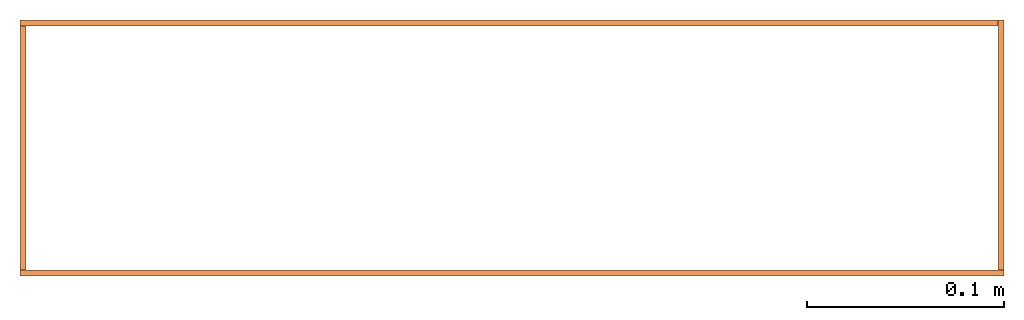
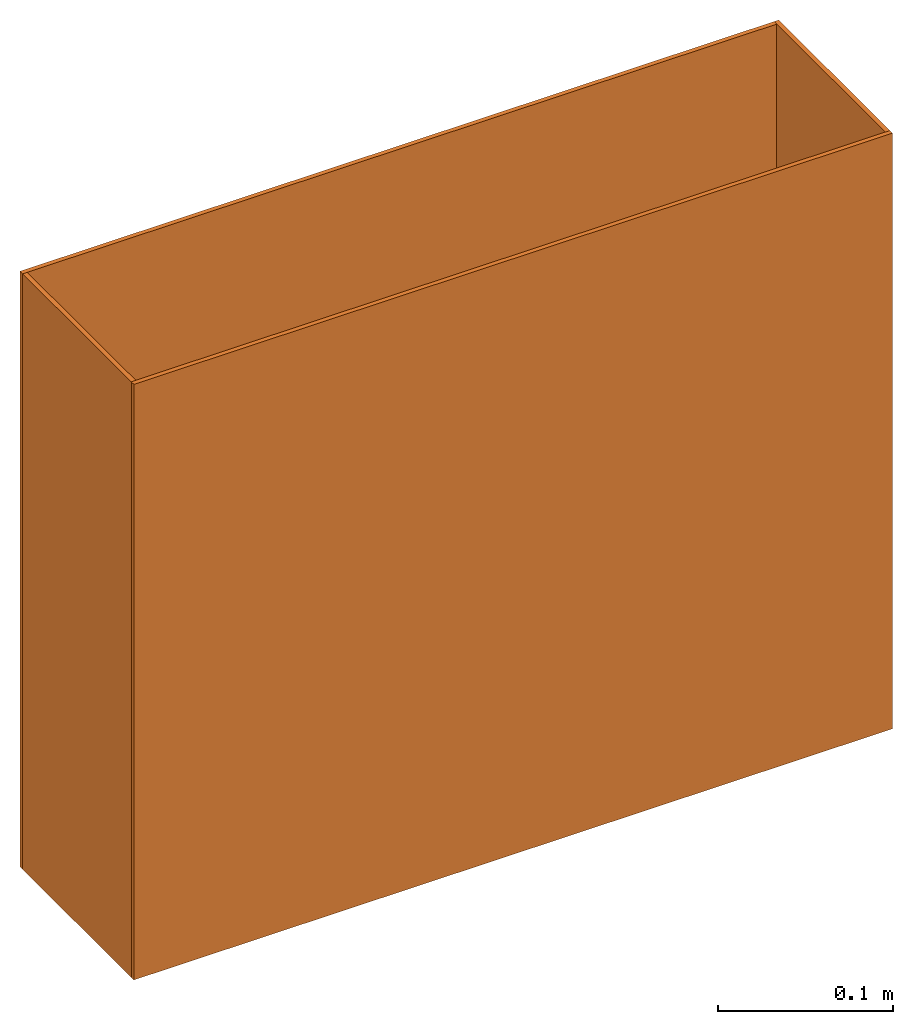
# One storey: 4 proxies.
"""IFC2X3 building model written with IfcOpenShell, lengths in metres."""

from ifc_helpers import new_model, entity, si_unit, converted_unit, derived_unit, money_unit, direction, frame, origin_with_axes, place, context, subcontext, project, spatial, polyline, outline, extrude, boolean, faceted_brep, material, type_object, element, save


model = new_model("IFC2X3")

# Units and contexts
model_context = context("Model", 3, precision=1e-05, world=origin_with_axes(), true_north=direction((0.0, 1.0)))
plan_context = context("Plan", 3, precision=1e-05, world=origin_with_axes(), true_north=direction((0.0, 1.0)))
body_context = subcontext(model_context, "Body", "Model", "MODEL_VIEW")
ifc_project = project(units=[si_unit("LENGTHUNIT", "METRE"), si_unit("AREAUNIT", "SQUARE_METRE"), si_unit("VOLUMEUNIT", "CUBIC_METRE"), converted_unit("PLANEANGLEUNIT", "DEGREE", entity("IfcPlaneAngleMeasure", 0.0174532925199), si_unit("PLANEANGLEUNIT", "RADIAN"), dimensions=[0, 0, 0, 0, 0, 0, 0]), si_unit("SOLIDANGLEUNIT", "STERADIAN"), money_unit("CHF"), converted_unit("TIMEUNIT", "Year", entity("IfcTimeMeasure", 31556926.0), si_unit("TIMEUNIT", "SECOND"), dimensions=[0, 0, 1, 0, 0, 0, 0]), si_unit("MASSUNIT", "GRAM", prefix="KILO"), si_unit("THERMODYNAMICTEMPERATUREUNIT", "DEGREE_CELSIUS"), si_unit("LUMINOUSINTENSITYUNIT", "LUMEN"), si_unit("ENERGYUNIT", "JOULE", prefix="MEGA"), derived_unit("THERMALCONDUCTANCEUNIT", [(si_unit("POWERUNIT", "WATT"), 1), (si_unit("LENGTHUNIT", "METRE"), -1), (si_unit("THERMODYNAMICTEMPERATUREUNIT", "KELVIN"), -1)]), derived_unit("SPECIFICHEATCAPACITYUNIT", [(si_unit("ENERGYUNIT", "JOULE"), 1), (si_unit("MASSUNIT", "GRAM", prefix="KILO"), -1), (si_unit("THERMODYNAMICTEMPERATUREUNIT", "KELVIN"), -1)]), derived_unit("MASSDENSITYUNIT", [(si_unit("MASSUNIT", "GRAM", prefix="KILO"), 1), (si_unit("VOLUMEUNIT", "CUBIC_METRE"), -1)])], contexts=[model_context, plan_context])

# Site, building, storey
site_placement = place(None, origin_with_axes())
site = spatial("IfcSite", under=ifc_project, at=site_placement, CompositionType="ELEMENT")
building_placement = place(site_placement, origin_with_axes())
building = spatial("IfcBuilding", under=site, at=building_placement, CompositionType="ELEMENT")
storey_placement = place(building_placement, frame((0.0, 0.0, -2.96), z_axis=(0.0, 0.0, 1.0), x_axis=(1.0, 0.0, 0.0)))
storey = spatial("IfcBuildingStorey", under=building, at=storey_placement, Name="UG01", CompositionType="ELEMENT", Elevation=-2.96)

# Proxies
ifc_material = material(Name="Metall, Stahl")
building_element_proxy_type = type_object("IfcBuildingElementProxyType", Name="Metall, Stahl 3", PredefinedType="NOTDEFINED")
proxy_1_placement = place(storey_placement, frame((1.55655524907, 0.965872173005, 2.545), z_axis=(0.0, 0.0, 1.0), x_axis=(1.0, 0.0, 0.0)))
element("IfcBuildingElementProxy", 1, at=proxy_1_placement, inside=storey, type_object=building_element_proxy_type, material=ifc_material, Name="Wand-026", context=body_context, shape_type="SweptSolid", body=[
    extrude(outline(polyline([(0.0, 0.0), (0.5, 0.0), (0.5, 0.003), (0.0, 0.003), (0.0, 0.0)])), origin_with_axes(), (0.0, 0.0, 1.0), 0.415),
])
proxy_2_placement = place(storey_placement, frame((2.05655524907, 0.965872173005, 2.545), z_axis=(0.0, 0.0, 1.0), x_axis=(0.0, 1.0, 0.0)))
element("IfcBuildingElementProxy", 2, at=proxy_2_placement, inside=storey, type_object=building_element_proxy_type, material=ifc_material, Name="Wand-027", context=body_context, shape_type="CSG", body=[
    boolean("DIFFERENCE", extrude(outline(polyline([(0.0, 0.0), (0.13, 0.0), (0.13, 0.003), (0.0, 0.003), (0.0, 0.0)])), origin_with_axes(), (0.0, 0.0, 1.0), 0.415), faceted_brep([(0.003, 0.0, 0.0), (0.003, 0.0, 0.415), (0.0, 0.0, 0.415), (0.0, 0.0, 0.0), (0.003, 0.003, 0.415), (0.003, 0.003, 0.0), (0.0, 0.003, 0.415), (0.0, 0.003, 0.0)], [[[0, 1, 2, 3]], [[4, 1, 0, 5]], [[1, 4, 6, 2]], [[6, 7, 3, 2]], [[5, 0, 3, 7]], [[4, 5, 7, 6]]])),
])
proxy_3_placement = place(storey_placement, frame((2.05655524907, 1.09587217301, 2.545), z_axis=(0.0, 0.0, 1.0), x_axis=(-1.0, 0.0, 0.0)))
element("IfcBuildingElementProxy", 3, at=proxy_3_placement, inside=storey, type_object=building_element_proxy_type, material=ifc_material, Name="Wand-028", context=body_context, shape_type="CSG", body=[
    boolean("DIFFERENCE", extrude(outline(polyline([(0.0, 0.0), (0.5, 0.0), (0.5, 0.003), (0.0, 0.003), (0.0, 0.0)])), origin_with_axes(), (0.0, 0.0, 1.0), 0.415), faceted_brep([(0.003, 0.0, 0.0), (0.003, 0.0, 0.415), (0.0, 0.0, 0.415), (0.0, 0.0, 0.0), (0.003, 0.003, 0.415), (0.003, 0.003, 0.0), (0.0, 0.003, 0.415), (0.0, 0.003, 0.0)], [[[0, 1, 2, 3]], [[4, 1, 0, 5]], [[1, 4, 6, 2]], [[6, 7, 3, 2]], [[5, 0, 3, 7]], [[4, 5, 7, 6]]])),
])
proxy_4_placement = place(storey_placement, frame((1.55655524907, 1.09587217301, 2.545), z_axis=(0.0, 0.0, 1.0), x_axis=(0.0, -1.0, 0.0)))
element("IfcBuildingElementProxy", 4, at=proxy_4_placement, inside=storey, type_object=building_element_proxy_type, material=ifc_material, Name="Wand-029", context=body_context, shape_type="CSG", body=[
    boolean("DIFFERENCE", boolean("DIFFERENCE", extrude(outline(polyline([(0.0, 0.0), (0.13, 0.0), (0.13, 0.003), (0.0, 0.003), (0.0, 0.0)])), origin_with_axes(), (0.0, 0.0, 1.0), 0.415), faceted_brep([(0.127, 0.003, 0.0), (0.127, 0.003, 0.415), (0.13, 0.003, 0.415), (0.13, 0.003, 0.0), (0.127, 0.0, 0.415), (0.127, 0.0, 0.0), (0.13, 0.0, 0.415), (0.13, 0.0, 0.0)], [[[0, 1, 2, 3]], [[4, 1, 0, 5]], [[1, 4, 6, 2]], [[6, 7, 3, 2]], [[5, 0, 3, 7]], [[4, 5, 7, 6]]])), faceted_brep([(0.003, 0.0, 0.415), (0.003, 0.003, 0.415), (0.0, 0.003, 0.415), (0.0, 0.0, 0.415), (0.003, 0.003, 0.0), (0.003, 0.0, 0.0), (0.0, 0.003, 0.0), (0.0, 0.0, 0.0)], [[[0, 1, 2, 3]], [[4, 1, 0, 5]], [[1, 4, 6, 2]], [[2, 6, 7, 3]], [[5, 0, 3, 7]], [[4, 5, 7, 6]]])),
])

save(model, "model.ifc")
